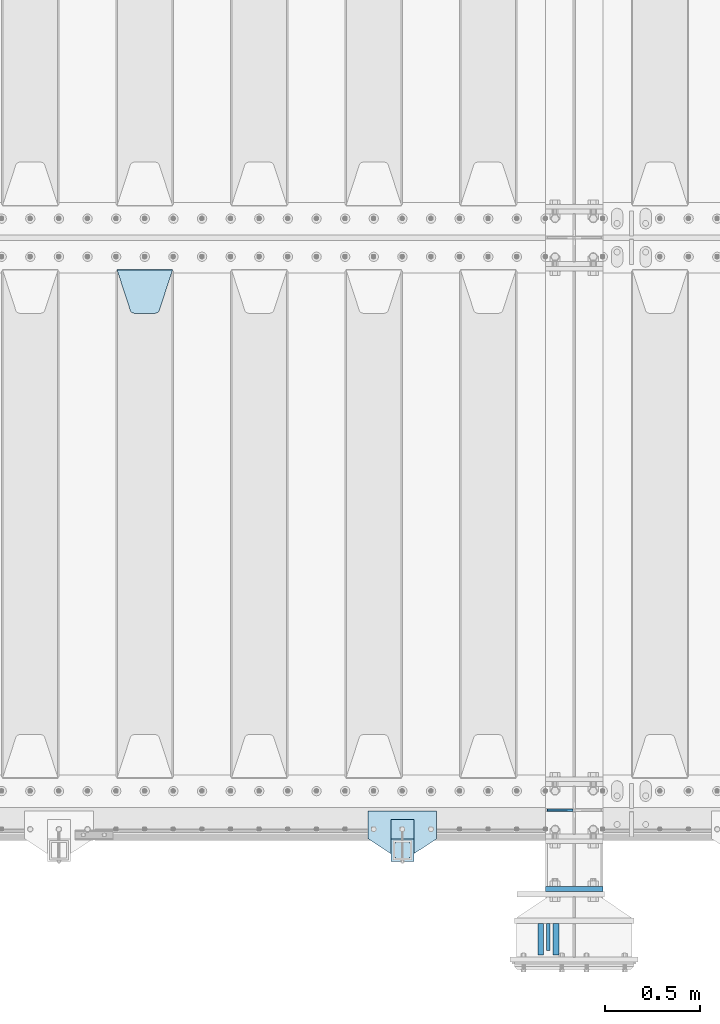
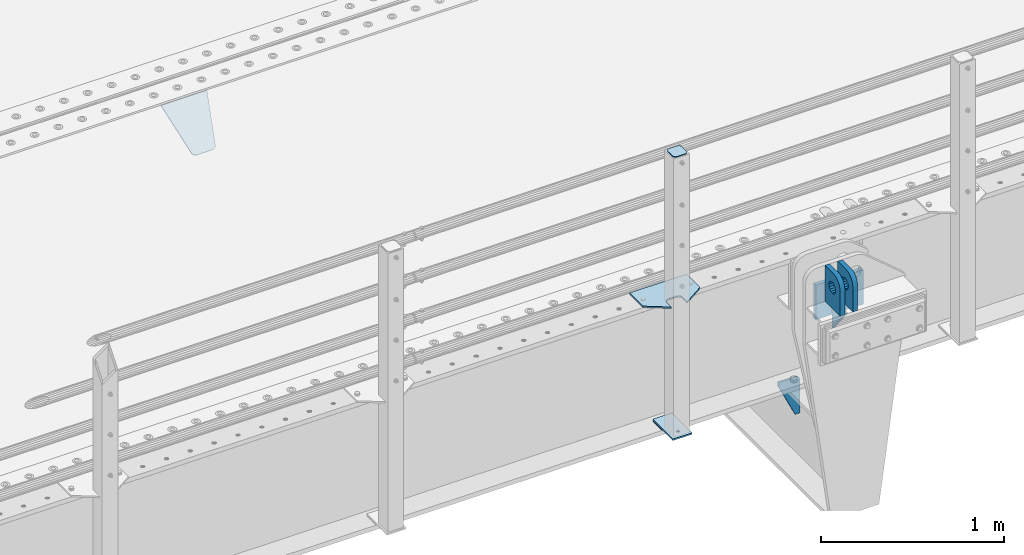
# One storey, part 210 of 257: 10 plates.
"""IFC2X3 building model written with IfcOpenShell, lengths in millimetres."""

from ifc_helpers import new_model, si_unit, frame, origin_with_axes, place, context, subcontext, project, spatial, faceted_brep, material, type_object, element, save


model = new_model("IFC2X3")

# Units and contexts
model_context = context("Model", 3, precision=1e-05, world=origin_with_axes())
body_context = subcontext(model_context, "Body", "Model", "MODEL_VIEW")
ifc_project = project(units=[si_unit("LENGTHUNIT", "METRE", prefix="MILLI"), si_unit("AREAUNIT", "SQUARE_METRE"), si_unit("VOLUMEUNIT", "CUBIC_METRE"), si_unit("MASSUNIT", "GRAM", prefix="KILO"), si_unit("TIMEUNIT", "SECOND"), si_unit("PLANEANGLEUNIT", "RADIAN"), si_unit("SOLIDANGLEUNIT", "STERADIAN"), si_unit("THERMODYNAMICTEMPERATUREUNIT", "DEGREE_CELSIUS"), si_unit("LUMINOUSINTENSITYUNIT", "LUMEN")], contexts=[model_context])

# Site, building, storey
site_placement = place(None, origin_with_axes())
site = spatial("IfcSite", under=ifc_project, at=site_placement, CompositionType="ELEMENT")
building_placement = place(site_placement, origin_with_axes())
building = spatial("IfcBuilding", under=site, at=building_placement, Name="Standard", CompositionType="ELEMENT")
storey_placement = place(building_placement, origin_with_axes())
storey = spatial("IfcBuildingStorey", under=building, at=storey_placement, Name="Undefined", CompositionType="ELEMENT", Elevation=0.0)

# Plates
ifc_material_1 = material(Name="STEEL/S355N")
plate_type_1 = type_object("IfcPlateType", PredefinedType="NOTDEFINED")
plate_1_placement = place(storey_placement, frame((54564.5000000687, -735.000000003108, -14.0000195365101), z_axis=(0.0, 0.0, -1.0), x_axis=(0.0, 1.0, 0.0)))
element("IfcPlate", 1, at=plate_1_placement, inside=storey, type_object=plate_type_1, material=ifc_material_1, context=body_context, shape_type="Brep", body=[
    faceted_brep([(0.0, -10.0, 0.0), (140.0, -10.0, 180.0), (140.0, 10.0, 180.0), (0.0, 10.0, 0.0), (140.0, -10.0, -1.81898940354586e-12), (140.0, 10.0, -1.81898940354586e-12)], [[[0, 1, 2, 3]], [[1, 4, 5, 2]], [[4, 0, 3, 5]], [[5, 3, 2]], [[4, 1, 0]]]),
])
plate_type_2 = type_object("IfcPlateType", PredefinedType="NOTDEFINED")
plate_2_placement = place(storey_placement, frame((54604.500000067, -595.00000000309, -1.95365428226069e-05), z_axis=(0.0, -1.0, 0.0), x_axis=(0.0, 0.0, 1.0)))
element("IfcPlate", 2, at=plate_2_placement, inside=storey, type_object=plate_type_2, material=ifc_material_1, context=body_context, shape_type="Brep", body=[
    faceted_brep([(113.837049096081, 14.9999999525899, 53.8370489460558), (113.837049096081, -15.0000000474101, 53.8370492460563), (125.840713002475, -15.0000001276203, 45.8164574470411), (125.840713002475, 14.9999998723797, 45.8164571470406), (105.816457297066, 15.0000000726213, 65.8407128524505), (105.816457297066, -14.9999999273787, 65.8407131524509), (102.999999999984, 15.0000002142187, 79.9999998499588), (102.999999999984, -14.9999997857813, 80.0000001499593), (105.816457297066, 15.0000003558089, 94.1592868474672), (105.816457297066, -14.9999996441911, 94.1592871474677), (113.837049096081, 15.0000004758476, 106.162950753862), (113.837049096081, -14.9999995241524, 106.162951053862), (125.840713002475, 15.0000005560505, 114.183542552877), (125.840713002475, -14.9999994439495, 114.183542852878), (139.999999999984, 15.0000005842157, 116.999999849959), (139.999999999984, -14.9999994157843, 117.000000149959), (154.159286997492, 15.0000005560505, 114.183542552877), (154.159286997492, -14.9999994439495, 114.183542852878), (166.162950903886, 15.0000004758476, 106.162950753862), (166.162950903886, -14.9999995241524, 106.162951053862), (174.183542702901, 15.0000003558089, 94.1592868474672), (174.183542702901, -14.9999996441911, 94.1592871474677), (176.999999999984, 15.0000002142187, 79.9999998499588), (176.999999999984, -14.9999997857813, 80.0000001499593), (174.183542702901, 15.0000000726213, 65.8407128524505), (174.183542702901, -14.9999999273787, 65.8407131524509), (166.162950903886, 14.9999999525899, 53.8370489460558), (166.162950903886, -15.0000000474101, 53.8370492460563), (154.159286997492, 14.9999998723797, 45.8164571470406), (154.159286997492, -15.0000001276203, 45.8164574470411), (139.999999999984, 14.9999998442145, 42.9999998499588), (139.999999999984, -15.0000001557855, 43.0000001499593), (240.000015258789, -14.9999999999927, -2.03726813197136e-10), (240.001666876698, -15.0, 94.9959403776247), (237.616787699976, -14.9999999999927, 113.113322498937), (230.624045898169, -14.9999999999927, 129.996116868069), (219.499985670386, -14.9999999999927, 144.493787979865), (205.002693976271, -14.9999999999927, 155.618342674454), (188.120138118986, -14.9999999999927, 162.611660295068), (170.002837349484, -14.9999999999927, 164.997157401463), (-1.40620068123098e-06, -14.9999999999927, 165.000000000002), (0.0, -15.0, 0.0), (0.0, 15.0, 0.0), (240.000015258789, 15.0000000000073, -2.05545802600682e-10), (240.001666876698, 15.0, 94.9959403776229), (237.616787699976, 15.0000000000073, 113.113322498935), (230.624045898169, 15.0000000000073, 129.996116868067), (219.499985670386, 15.0000000000073, 144.493787979864), (205.002693976271, 15.0000000000073, 155.618342674452), (188.120138118986, 15.0000000000073, 162.611660295066), (170.002837349484, 15.0000000000073, 164.997157401462), (-1.40620068123098e-06, 15.0000000000073, 165.000000000002)], [[[0, 1, 2, 3]], [[4, 5, 1, 0]], [[6, 7, 5, 4]], [[8, 9, 7, 6]], [[10, 11, 9, 8]], [[12, 13, 11, 10]], [[14, 15, 13, 12]], [[16, 17, 15, 14]], [[18, 19, 17, 16]], [[20, 21, 19, 18]], [[22, 23, 21, 20]], [[24, 25, 23, 22]], [[26, 27, 25, 24]], [[28, 29, 27, 26]], [[30, 31, 29, 28]], [[3, 2, 31, 30]], [[32, 33, 34, 35, 36, 37, 38, 39, 40, 41], [19, 21, 23, 25, 27, 29, 31, 2, 1, 5, 7, 9, 11, 13, 15, 17]], [[32, 41, 42, 43]], [[33, 32, 43, 44]], [[34, 33, 44, 45]], [[35, 34, 45, 46]], [[36, 35, 46, 47]], [[37, 36, 47, 48]], [[38, 37, 48, 49]], [[39, 38, 49, 50]], [[40, 39, 50, 51]], [[41, 40, 51, 42]], [[50, 49, 48, 47, 46, 45, 44, 43, 42, 51], [10, 8, 6, 4, 0, 3, 30, 28, 26, 24, 22, 20, 18, 16, 14, 12]]]),
])
plate_3_placement = place(storey_placement, frame((54524.5000000687, -595.00000000309, -1.95365428226069e-05), z_axis=(0.0, -1.0, 0.0), x_axis=(0.0, 0.0, 1.0)))
element("IfcPlate", 3, at=plate_3_placement, inside=storey, type_object=plate_type_2, material=ifc_material_1, context=body_context, shape_type="Brep", body=[
    faceted_brep([(113.837049096081, 14.9999999525899, 53.8370489460558), (113.837049096081, -15.0000000474101, 53.8370492460563), (125.840713002475, -15.0000001276203, 45.8164574470411), (125.840713002475, 14.9999998723797, 45.8164571470406), (105.816457297066, 15.0000000726213, 65.8407128524505), (105.816457297066, -14.9999999273787, 65.8407131524509), (102.999999999984, 15.0000002142187, 79.9999998499588), (102.999999999984, -14.9999997857813, 80.0000001499593), (105.816457297066, 15.0000003558089, 94.1592868474672), (105.816457297066, -14.9999996441911, 94.1592871474677), (113.837049096081, 15.0000004758476, 106.162950753862), (113.837049096081, -14.9999995241524, 106.162951053862), (125.840713002475, 15.0000005560505, 114.183542552877), (125.840713002475, -14.9999994439495, 114.183542852878), (139.999999999984, 15.0000005842157, 116.999999849959), (139.999999999984, -14.9999994157843, 117.000000149959), (154.159286997492, 15.0000005560505, 114.183542552877), (154.159286997492, -14.9999994439495, 114.183542852878), (166.162950903886, 15.0000004758476, 106.162950753862), (166.162950903886, -14.9999995241524, 106.162951053862), (174.183542702901, 15.0000003558089, 94.1592868474672), (174.183542702901, -14.9999996441911, 94.1592871474677), (176.999999999984, 15.0000002142187, 79.9999998499588), (176.999999999984, -14.9999997857813, 80.0000001499593), (174.183542702901, 15.0000000726213, 65.8407128524505), (174.183542702901, -14.9999999273787, 65.8407131524509), (166.162950903886, 14.9999999525899, 53.8370489460558), (166.162950903886, -15.0000000474101, 53.8370492460563), (154.159286997492, 14.9999998723797, 45.8164571470406), (154.159286997492, -15.0000001276203, 45.8164574470411), (139.999999999984, 14.9999998442145, 42.9999998499588), (139.999999999984, -15.0000001557855, 43.0000001499593), (240.000015258789, -14.9999999999927, -2.03726813197136e-10), (240.0, -14.9999999999927, 95.0), (237.614807840235, -14.9999999999927, 113.117333157177), (230.621778264911, -14.9999999999927, 130.0), (219.497474683058, -14.9999999999927, 144.497474683059), (205.0, -14.9999999999927, 155.621778264911), (188.117333157176, -14.9999999999927, 162.614807840235), (170.0, -14.9999999999927, 165.0), (-1.40620068123098e-06, -14.9999999999927, 165.000000000002), (0.0, -15.0, 0.0), (0.0, 15.0, 0.0), (240.000015258789, 15.0000000000073, -2.05545802600682e-10), (240.0, 15.0000000000073, 95.0000000000018), (237.614807840235, 15.0000000000073, 113.117333157177), (230.621778264911, 15.0000000000073, 130.000000000002), (219.497474683058, 15.0000000000073, 144.497474683059), (205.0, 15.0000000000073, 155.621778264911), (188.117333157176, 15.0000000000073, 162.614807840237), (170.0, 15.0000000000073, 165.000000000002), (-1.40620068123098e-06, 15.0000000000073, 165.000000000002)], [[[0, 1, 2, 3]], [[4, 5, 1, 0]], [[6, 7, 5, 4]], [[8, 9, 7, 6]], [[10, 11, 9, 8]], [[12, 13, 11, 10]], [[14, 15, 13, 12]], [[16, 17, 15, 14]], [[18, 19, 17, 16]], [[20, 21, 19, 18]], [[22, 23, 21, 20]], [[24, 25, 23, 22]], [[26, 27, 25, 24]], [[28, 29, 27, 26]], [[30, 31, 29, 28]], [[3, 2, 31, 30]], [[32, 33, 34, 35, 36, 37, 38, 39, 40, 41], [19, 21, 23, 25, 27, 29, 31, 2, 1, 5, 7, 9, 11, 13, 15, 17]], [[32, 41, 42, 43]], [[33, 32, 43, 44]], [[34, 33, 44, 45]], [[35, 34, 45, 46]], [[36, 35, 46, 47]], [[37, 36, 47, 48]], [[38, 37, 48, 49]], [[39, 38, 49, 50]], [[40, 39, 50, 51]], [[41, 40, 51, 42]], [[50, 49, 48, 47, 46, 45, 44, 43, 42, 51], [10, 8, 6, 4, 0, 3, 30, 28, 26, 24, 22, 20, 18, 16, 14, 12]]]),
])
plate_type_3 = type_object("IfcPlateType", PredefinedType="NOTDEFINED")
plate_4_placement = place(storey_placement, frame((54693.4999999998, 4.21766799263423e-09, -915.000019536855), z_axis=(0.0, 0.0, -1.0), x_axis=(-1.0, 0.0, 0.0)))
element("IfcPlate", 4, at=plate_4_placement, inside=storey, type_object=plate_type_3, material=ifc_material_1, context=body_context, shape_type="Brep", body=[
    faceted_brep([(0.0, -5.0, 27.0), (0.0, -5.0, 250.0), (0.0, 5.0, 250.0), (0.0, 5.0, 27.0), (30.0, -5.0, 250.0), (30.0, 5.0, 250.0), (135.0, -5.0, 30.0), (135.0, 5.0, 30.0), (135.0, -5.0, 0.0), (135.0, 5.0, 0.0), (27.0, -5.0, 0.0), (27.0, 5.0, 0.0), (22.311499202995, -5.0, 0.410190668670339), (22.311499202995, 5.0, 0.410190668670339), (17.7654561302043, -5.0, 1.62829923878053), (17.7654561302043, 5.0, 1.62829923878053), (13.5, -5.0, 3.6173140978201), (13.5, 5.0, 3.6173140978201), (9.64473453846585, -5.0, 6.31680003578754), (9.64473453846585, 5.0, 6.31680003578754), (6.31680003579095, -5.0, 9.64473453846347), (6.31680003579095, 5.0, 9.64473453846347), (3.61731409782078, -5.0, 13.5), (3.61731409782078, 5.0, 13.5), (1.62829923877871, -5.0, 17.765456130207), (1.62829923877871, 5.0, 17.765456130207), (0.410190668670111, -5.0, 22.3114992029929), (0.410190668670111, 5.0, 22.3114992029929)], [[[0, 1, 2, 3]], [[1, 4, 5, 2]], [[4, 6, 7, 5]], [[6, 8, 9, 7]], [[8, 10, 11, 9]], [[10, 12, 13, 11]], [[12, 14, 15, 13]], [[14, 16, 17, 15]], [[16, 18, 19, 17]], [[18, 20, 21, 19]], [[20, 22, 23, 21]], [[22, 24, 25, 23]], [[24, 26, 27, 25]], [[26, 0, 3, 27]], [[5, 7, 9, 11, 13, 15, 17, 19, 21, 23, 25, 27, 3, 2]], [[26, 24, 22, 20, 18, 16, 14, 12, 10, 8, 6, 4, 1, 0]]]),
])
plate_type_4 = type_object("IfcPlateType", PredefinedType="NOTDEFINED")
plate_5_placement = place(storey_placement, frame((52305.0, 2831.76776695594, -1.767766952965), z_axis=(0.0, -0.707106781186548, -0.707106781186547), x_axis=(1.0, 0.0, 0.0)))
element("IfcPlate", 5, at=plate_5_placement, inside=storey, type_object=plate_type_4, material=ifc_material_1, context=body_context, shape_type="Brep", body=[
    faceted_brep([(0.0, -2.5, 0.0), (69.345504679477, -2.50000000000091, 300.17173142483), (69.345504679477, 2.5, 300.171731424831), (0.0, 2.5, 0.0), (70.927406119954, -2.50000000000091, 304.8974424154), (70.927406119954, 2.5, 304.8974424154), (73.3818627772271, -2.50000000000091, 309.234538108527), (73.3818627772271, 2.49999999999909, 309.234538108527), (76.6187032999587, -2.5, 313.023683126103), (76.6187032999587, 2.5, 313.023683126103), (80.5190132705029, -2.5, 316.125672595372), (80.5190132705029, 2.5, 316.125672595371), (84.9395038596849, -2.5, 318.426546230476), (84.9395038596849, 2.5, 318.426546230477), (89.7177759439219, -2.5, 319.841774983275), (89.7177759439219, 2.5, 319.841774983275), (94.6782862926484, -2.5, 320.319366455079), (94.6782862926484, 2.5, 320.319366455079), (195.321713707352, -2.5, 320.319366455079), (195.321713707352, 2.5, 320.319366455079), (200.282224056078, -2.5, 319.841774983275), (200.282224056078, 2.49999999999909, 319.841774983275), (205.060496140315, -2.5, 318.426546230476), (205.060496140315, 2.49999999999909, 318.426546230475), (209.480986729497, -2.5, 316.125672595371), (209.480986729497, 2.5, 316.125672595371), (213.381296700041, -2.50000000000091, 313.023683126102), (213.381296700041, 2.5, 313.023683126103), (216.618137222766, -2.50000000000091, 309.234538108527), (216.618137222766, 2.5, 309.234538108527), (219.072593880039, -2.5, 304.897442415399), (219.072593880039, 2.5, 304.897442415399), (220.654495320523, -2.50000000000091, 300.17173142483), (220.654495320523, 2.5, 300.171731424831), (290.0, -2.50000000000091, 0.0), (290.0, 2.5, 9.09494701772928e-13)], [[[0, 1, 2, 3]], [[1, 4, 5, 2]], [[4, 6, 7, 5]], [[6, 8, 9, 7]], [[8, 10, 11, 9]], [[10, 12, 13, 11]], [[12, 14, 15, 13]], [[14, 16, 17, 15]], [[16, 18, 19, 17]], [[18, 20, 21, 19]], [[20, 22, 23, 21]], [[22, 24, 25, 23]], [[24, 26, 27, 25]], [[26, 28, 29, 27]], [[28, 30, 31, 29]], [[30, 32, 33, 31]], [[32, 34, 35, 33]], [[34, 0, 3, 35]], [[5, 7, 9, 11, 13, 15, 17, 19, 21, 23, 25, 27, 29, 31, 33, 35, 3, 2]], [[34, 32, 30, 28, 26, 24, 22, 20, 18, 16, 14, 12, 10, 8, 6, 4, 1, 0]]]),
])
ifc_material_2 = material(Name="STEEL/S355J2")
plate_type_5 = type_object("IfcPlateType", PredefinedType="NOTDEFINED")
plate_6_placement = place(storey_placement, frame((53980.0, -4.99999999999636, 5.00000000004911), z_axis=(0.0, -1.0, 0.0), x_axis=(-1.0, 0.0, 0.0)))
element("IfcPlate", 6, at=plate_6_placement, inside=storey, type_object=plate_type_5, material=ifc_material_2, context=body_context, shape_type="Brep", body=[
    faceted_brep([(0.0, -5.0, 0.0), (2.31396552408114e-06, -5.0, 145.0), (2.31396552408114e-06, 5.0, 145.0), (0.0, 5.0, 0.0), (130.0, -5.0, 230.0), (130.0, 5.0, 230.0), (130.0, -5.0, 180.0), (130.0, 5.0, 180.0), (130.48036798992, -5.0, 175.122741949597), (130.48036798992, 5.0, 175.122741949597), (131.903011687216, -5.0, 170.432914190873), (131.903011687216, 5.0, 170.432914190873), (134.213259692435, -5.0, 166.11074417451), (134.213259692435, 5.0, 166.11074417451), (137.322330470335, -5.0, 162.322330470337), (137.322330470335, 5.0, 162.322330470337), (141.110744174512, -5.0, 159.213259692437), (141.110744174512, 5.0, 159.213259692437), (145.432914190875, -5.0, 156.903011687218), (145.432914190875, 5.0, 156.903011687218), (150.122741949599, -5.0, 155.48036798992), (150.122741949599, 5.0, 155.48036798992), (155.0, -5.0, 155.0), (155.0, 5.0, 155.0), (205.0, -5.0, 155.0), (205.0, 5.0, 155.0), (209.877258050401, -5.0, 155.48036798992), (209.877258050401, 5.0, 155.48036798992), (214.567085809125, -5.0, 156.903011687218), (214.567085809125, 5.0, 156.903011687218), (218.889255825488, -5.0, 159.213259692437), (218.889255825488, 5.0, 159.213259692437), (222.677669529665, -5.0, 162.322330470337), (222.677669529665, 5.0, 162.322330470337), (225.786740307565, -5.0, 166.11074417451), (225.786740307565, 5.0, 166.11074417451), (228.096988312784, -5.0, 170.432914190873), (228.096988312784, 5.0, 170.432914190873), (229.51963201008, -5.0, 175.122741949597), (229.51963201008, 5.0, 175.122741949597), (230.0, -5.0, 180.0), (230.0, 5.0, 180.0), (230.0, -5.0, 230.0), (230.0, 5.0, 230.0), (360.0, -5.0, 145.0), (360.0, 5.0, 145.0), (360.0, -5.0, -7.27595761418343e-12), (360.0, 5.0, -7.27595761418343e-12)], [[[0, 1, 2, 3]], [[1, 4, 5, 2]], [[4, 6, 7, 5]], [[6, 8, 9, 7]], [[8, 10, 11, 9]], [[10, 12, 13, 11]], [[12, 14, 15, 13]], [[14, 16, 17, 15]], [[16, 18, 19, 17]], [[18, 20, 21, 19]], [[20, 22, 23, 21]], [[22, 24, 25, 23]], [[24, 26, 27, 25]], [[26, 28, 29, 27]], [[28, 30, 31, 29]], [[30, 32, 33, 31]], [[32, 34, 35, 33]], [[34, 36, 37, 35]], [[36, 38, 39, 37]], [[38, 40, 41, 39]], [[40, 42, 43, 41]], [[42, 44, 45, 43]], [[44, 46, 47, 45]], [[46, 0, 3, 47]], [[5, 7, 9, 11, 13, 15, 17, 19, 21, 23, 25, 27, 29, 31, 33, 35, 37, 39, 41, 43, 45, 47, 3, 2]], [[46, 44, 42, 40, 38, 36, 34, 32, 30, 28, 26, 24, 22, 20, 18, 16, 14, 12, 10, 8, 6, 4, 1, 0]]]),
])
plate_type_6 = type_object("IfcPlateType", PredefinedType="NOTDEFINED")
plate_7_placement = place(storey_placement, frame((53859.9999999999, -50.0000000002074, -850.000000000002), z_axis=(0.0, -1.0, 0.0), x_axis=(-1.0, 0.0, 0.0)))
element("IfcPlate", 7, at=plate_7_placement, inside=storey, type_object=plate_type_6, material=ifc_material_2, context=body_context, shape_type="Brep", body=[
    faceted_brep([(53.6360389691836, -5.0, 176.363961030469), (53.6360389691836, 5.0, 176.363961030469), (59.9999999998618, 5.0, 178.999999999791), (59.9999999998618, -5.0, 178.999999999791), (66.3639610305399, 5.0, 176.363961030469), (66.3639610305399, -5.0, 176.363961030469), (68.9999999998618, 5.0, 169.999999999791), (68.9999999998618, -5.0, 169.999999999791), (66.3639610305399, 5.0, 163.636038969113), (66.3639610305399, -5.0, 163.636038969113), (59.9999999998618, 5.0, 160.999999999791), (59.9999999998618, -5.0, 160.999999999791), (53.6360389691836, 5.0, 163.636038969113), (53.6360389691836, -5.0, 163.636038969113), (50.9999999998618, 5.0, 169.999999999791), (50.9999999998618, -5.0, 169.999999999791), (120.0, -5.0, 0.0), (120.0, -5.0, 220.0), (0.0, -5.0, 220.0), (0.0, -5.0, 0.0), (0.0, 5.0, 0.0), (120.0, 5.0, 0.0), (120.0, 5.0, 220.0), (0.0, 5.0, 220.0)], [[[0, 1, 2, 3]], [[3, 2, 4, 5]], [[5, 4, 6, 7]], [[7, 6, 8, 9]], [[9, 8, 10, 11]], [[11, 10, 12, 13]], [[13, 12, 14, 15]], [[15, 14, 1, 0]], [[16, 17, 18, 19], [11, 13, 15, 0, 3, 5, 7, 9]], [[16, 19, 20, 21]], [[17, 16, 21, 22]], [[18, 17, 22, 23]], [[19, 18, 23, 20]], [[22, 21, 20, 23], [2, 1, 14, 12, 10, 8, 6, 4]]]),
])
plate_type_7 = type_object("IfcPlateType", PredefinedType="NOTDEFINED")
plate_8_placement = place(storey_placement, frame((53755.9999999999, -166.000000000207, 1012.50000000001), z_axis=(0.0, -1.0, 0.0), x_axis=(1.0, 0.0, 0.0)))
element("IfcPlate", 8, at=plate_8_placement, inside=storey, type_object=plate_type_7, material=ifc_material_2, context=body_context, shape_type="Brep", body=[
    faceted_brep([(0.0, -2.5, 19.0), (0.0, -2.5, 69.0), (0.0, 2.5, 69.0), (0.0, 2.5, 19.0), (0.476369668547704, -2.5, 73.2278977451697), (0.476369668547704, 2.5, 73.2278977451697), (1.88159150985302, -2.5, 77.2437910432327), (1.88159150985302, 2.5, 77.2437910432327), (4.14520183311106, -2.5, 80.8463062353167), (4.14520183311106, 2.5, 80.8463062353167), (7.15369376468152, -2.5, 83.8547981668926), (7.15369376468152, 2.5, 83.8547981668926), (10.7562089567655, -2.5, 86.1184084901452), (10.7562089567655, 2.5, 86.1184084901452), (14.7721022548285, -2.5, 87.5236303314541), (14.7721022548285, 2.5, 87.5236303314541), (19.0, -2.5, 88.0), (19.0, 2.5, 88.0), (69.0, -2.5, 88.0), (69.0, 2.5, 88.0), (73.2278977451715, -2.5, 87.5236303314541), (73.2278977451715, 2.5, 87.5236303314541), (77.2437910432345, -2.5, 86.1184084901452), (77.2437910432345, 2.5, 86.1184084901452), (80.8463062353185, -2.5, 83.8547981668926), (80.8463062353185, 2.5, 83.8547981668926), (83.8547981668889, -2.5, 80.8463062353167), (83.8547981668889, 2.5, 80.8463062353167), (86.118408490147, -2.5, 77.2437910432327), (86.118408490147, 2.5, 77.2437910432327), (87.5236303314523, -2.5, 73.2278977451697), (87.5236303314523, 2.5, 73.2278977451697), (88.0, -2.5, 69.0), (88.0, 2.5, 69.0), (88.0, -2.5, 19.0), (88.0, 2.5, 19.0), (87.5236303314523, -2.5, 14.7721022548303), (87.5236303314523, 2.5, 14.7721022548303), (86.118408490147, -2.5, 10.7562089567673), (86.118408490147, 2.5, 10.7562089567673), (83.8547981668889, -2.5, 7.15369376468334), (83.8547981668889, 2.5, 7.15369376468334), (80.8463062353185, -2.5, 4.14520183310742), (80.8463062353185, 2.5, 4.14520183310742), (77.2437910432345, -2.5, 1.88159150985484), (77.2437910432345, 2.5, 1.88159150985484), (73.2278977451715, -2.5, 0.476369668545885), (73.2278977451715, 2.5, 0.476369668545885), (69.0, -2.5, 0.0), (69.0, 2.5, 0.0), (19.0, -2.5, 0.0), (19.0, 2.5, 0.0), (14.7721022548285, -2.5, 0.476369668545885), (14.7721022548285, 2.5, 0.476369668545885), (10.7562089567655, -2.5, 1.88159150985484), (10.7562089567655, 2.5, 1.88159150985484), (7.15369376468152, -2.5, 4.14520183310742), (7.15369376468152, 2.5, 4.14520183310742), (4.14520183311106, -2.5, 7.15369376468334), (4.14520183311106, 2.5, 7.15369376468334), (1.88159150985302, -2.5, 10.7562089567673), (1.88159150985302, 2.5, 10.7562089567673), (0.476369668547704, -2.5, 14.7721022548303), (0.476369668547704, 2.5, 14.7721022548303)], [[[0, 1, 2, 3]], [[1, 4, 5, 2]], [[4, 6, 7, 5]], [[6, 8, 9, 7]], [[8, 10, 11, 9]], [[10, 12, 13, 11]], [[12, 14, 15, 13]], [[14, 16, 17, 15]], [[16, 18, 19, 17]], [[18, 20, 21, 19]], [[20, 22, 23, 21]], [[22, 24, 25, 23]], [[24, 26, 27, 25]], [[26, 28, 29, 27]], [[28, 30, 31, 29]], [[30, 32, 33, 31]], [[32, 34, 35, 33]], [[34, 36, 37, 35]], [[36, 38, 39, 37]], [[38, 40, 41, 39]], [[40, 42, 43, 41]], [[42, 44, 45, 43]], [[44, 46, 47, 45]], [[46, 48, 49, 47]], [[48, 50, 51, 49]], [[50, 52, 53, 51]], [[52, 54, 55, 53]], [[54, 56, 57, 55]], [[56, 58, 59, 57]], [[58, 60, 61, 59]], [[60, 62, 63, 61]], [[62, 0, 3, 63]], [[5, 7, 9, 11, 13, 15, 17, 19, 21, 23, 25, 27, 29, 31, 33, 35, 37, 39, 41, 43, 45, 47, 49, 51, 53, 55, 57, 59, 61, 63, 3, 2]], [[62, 60, 58, 56, 54, 52, 50, 48, 46, 44, 42, 40, 38, 36, 34, 32, 30, 28, 26, 24, 22, 20, 18, 16, 14, 12, 10, 8, 6, 4, 1, 0]]]),
])
plate_type_8 = type_object("IfcPlateType", PredefinedType="NOTDEFINED")
plate_9_placement = place(storey_placement, frame((53859.9999999999, -50.0000000002074, -857.500000000002), z_axis=(0.0, -1.0, 0.0), x_axis=(-1.0, 0.0, 0.0)))
element("IfcPlate", 9, at=plate_9_placement, inside=storey, type_object=plate_type_8, material=ifc_material_2, context=body_context, shape_type="Brep", body=[
    faceted_brep([(0.0, -2.5, 0.0), (0.0, -2.5, 100.0), (0.0, 2.5, 100.0), (0.0, 2.5, 0.0), (120.0, -2.5, 100.0), (120.0, 2.5, 100.0), (120.0, -2.5, 0.0), (120.0, 2.5, 0.0)], [[[0, 1, 2, 3]], [[1, 4, 5, 2]], [[4, 6, 7, 5]], [[6, 0, 3, 7]], [[5, 7, 3, 2]], [[6, 4, 1, 0]]]),
])
plate_type_9 = type_object("IfcPlateType", PredefinedType="NOTDEFINED")
plate_10_placement = place(storey_placement, frame((54550.0, -412.499999995798, -240.000019536859), z_axis=(0.0, 0.0, 1.0), x_axis=(1.0, 0.0, 0.0)))
element("IfcPlate", 10, at=plate_10_placement, inside=storey, type_object=plate_type_9, material=ifc_material_1, context=body_context, shape_type="Brep", body=[
    faceted_brep([(0.0, -12.5, 0.0), (0.0, -12.5, 230.0), (0.0, 12.5, 230.0), (0.0, 12.5, 0.0), (300.0, -12.5, 230.0), (300.0, 12.5, 230.0), (300.0, -12.5, 0.0), (300.0, 12.5, 0.0)], [[[0, 1, 2, 3]], [[1, 4, 5, 2]], [[4, 6, 7, 5]], [[6, 0, 3, 7]], [[5, 7, 3, 2]], [[6, 4, 1, 0]]]),
])

save(model, "model.ifc")
